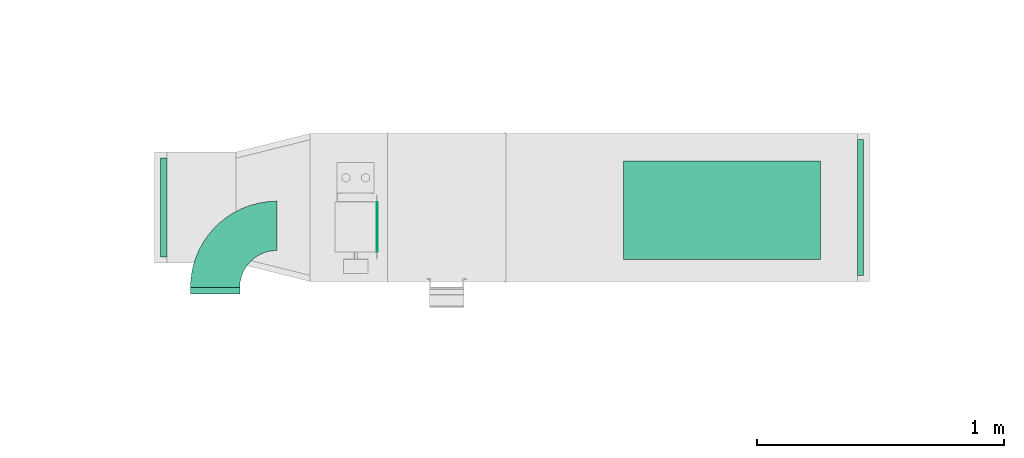
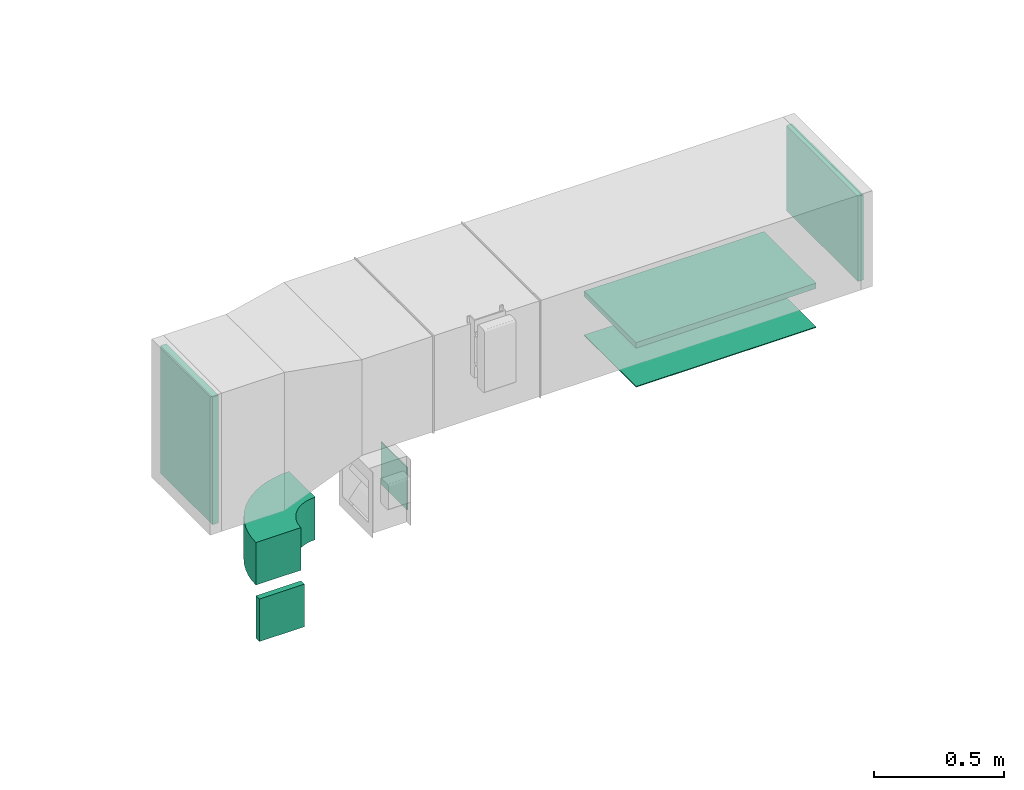
# One storey, part 5 of 10: 5 flow fittings, 2 flow terminals.
"""IFC2X3 building model written with IfcOpenShell, lengths in millimetres."""

from ifc_helpers import new_model, entity, si_unit, converted_unit, derived_unit, direction, frame, frame_2d, origin, origin_2d_with_axis, place, context, subcontext, project, spatial, polyline, circle_curve, parameter, trimmed, segment, composite_curve, rectangle, outline, extrude, source, transform, mapped, material, type_object, type_shapes, element, save


model = new_model("IFC2X3")

# Units and contexts
model_context = context("Model", 3, precision=0.01, world=origin(), true_north=direction((6.12303176911189e-17, 1.0)))
body_context = subcontext(model_context, "Body", "Model", "MODEL_VIEW")
ifc_project = project(units=[si_unit("LENGTHUNIT", "METRE", prefix="MILLI"), si_unit("AREAUNIT", "SQUARE_METRE"), si_unit("VOLUMEUNIT", "CUBIC_METRE"), converted_unit("PLANEANGLEUNIT", "DEGREE", entity("IfcRatioMeasure", 0.0174532925199433), si_unit("PLANEANGLEUNIT", "RADIAN"), dimensions=[0, 0, 0, 0, 0, 0, 0]), si_unit("MASSUNIT", "GRAM", prefix="KILO"), derived_unit("MASSDENSITYUNIT", [(si_unit("MASSUNIT", "GRAM", prefix="KILO"), 1), (si_unit("LENGTHUNIT", "METRE"), -3)]), derived_unit("MOMENTOFINERTIAUNIT", [(si_unit("LENGTHUNIT", "METRE"), 4)]), si_unit("TIMEUNIT", "SECOND"), si_unit("FREQUENCYUNIT", "HERTZ"), si_unit("THERMODYNAMICTEMPERATUREUNIT", "DEGREE_CELSIUS"), derived_unit("THERMALTRANSMITTANCEUNIT", [(si_unit("MASSUNIT", "GRAM", prefix="KILO"), 1), (si_unit("THERMODYNAMICTEMPERATUREUNIT", "KELVIN"), -1), (si_unit("TIMEUNIT", "SECOND"), -3)]), derived_unit("VOLUMETRICFLOWRATEUNIT", [(si_unit("LENGTHUNIT", "METRE"), 3), (si_unit("TIMEUNIT", "SECOND"), -1)]), derived_unit("MASSFLOWRATEUNIT", [(si_unit("MASSUNIT", "GRAM", prefix="KILO"), 1), (si_unit("TIMEUNIT", "SECOND"), -1)]), derived_unit("ROTATIONALFREQUENCYUNIT", [(si_unit("TIMEUNIT", "SECOND"), -1)]), si_unit("ELECTRICCURRENTUNIT", "AMPERE"), si_unit("ELECTRICVOLTAGEUNIT", "VOLT"), si_unit("POWERUNIT", "WATT"), si_unit("FORCEUNIT", "NEWTON", prefix="KILO"), si_unit("ILLUMINANCEUNIT", "LUX"), si_unit("LUMINOUSFLUXUNIT", "LUMEN"), si_unit("LUMINOUSINTENSITYUNIT", "CANDELA"), derived_unit("USERDEFINED", [(si_unit("MASSUNIT", "GRAM", prefix="KILO"), -1), (si_unit("LENGTHUNIT", "METRE"), -2), (si_unit("TIMEUNIT", "SECOND"), 3), (si_unit("LUMINOUSFLUXUNIT", "LUMEN"), 1)]), derived_unit("LINEARVELOCITYUNIT", [(si_unit("LENGTHUNIT", "METRE"), 1), (si_unit("TIMEUNIT", "SECOND"), -1)]), si_unit("PRESSUREUNIT", "PASCAL"), derived_unit("USERDEFINED", [(si_unit("LENGTHUNIT", "METRE"), -2), (si_unit("MASSUNIT", "GRAM", prefix="KILO"), 1), (si_unit("TIMEUNIT", "SECOND"), -2)]), derived_unit("LINEARFORCEUNIT", [(si_unit("MASSUNIT", "GRAM", prefix="KILO"), 1), (si_unit("LENGTHUNIT", "METRE"), 1), (si_unit("TIMEUNIT", "SECOND"), -2), (si_unit("LENGTHUNIT", "METRE"), -1)]), derived_unit("PLANARFORCEUNIT", [(si_unit("MASSUNIT", "GRAM", prefix="KILO"), 1), (si_unit("LENGTHUNIT", "METRE"), 1), (si_unit("TIMEUNIT", "SECOND"), -2), (si_unit("LENGTHUNIT", "METRE"), -2)])], contexts=[model_context])

# Site, building, storey
site_placement = place(None, origin())
site = spatial("IfcSite", under=ifc_project, at=site_placement, CompositionType="ELEMENT")
building_placement = place(site_placement, origin())
building = spatial("IfcBuilding", under=site, at=building_placement, CompositionType="ELEMENT")
storey_placement = place(building_placement, frame((0.0, 0.0, 8100.0)))
storey = spatial("IfcBuildingStorey", under=building, at=storey_placement, CompositionType="ELEMENT", Elevation=8100.0)

# Flow fittings
ifc_material_1 = material()
duct_fitting_type_1 = type_object("IfcDuctFittingType", PredefinedType="NOTDEFINED", material=ifc_material_1)
shared_shape_1 = source(origin(), body_context, "Body", "SweptSolid", [
    extrude(rectangle(XDim=800.0, YDim=26.096, at=origin_2d_with_axis()), frame((6.95, 0.0, -200.0), z_axis=(0.0, 0.0, 1.0), x_axis=(0.0, -1.0, 0.0)), (0.0, 0.0, 1.0), 400.0),
])
type_shapes(duct_fitting_type_1, [shared_shape_1])
flow_fitting_1_placement = place(storey_placement, frame((12300.13, 14784.08, 3000.0), z_axis=(0.0, 1.0, 0.0), x_axis=(0.0, 0.0, -1.0)))
element("IfcFlowFitting", 1, at=flow_fitting_1_placement, inside=storey, type_object=duct_fitting_type_1, material=ifc_material_1, context=body_context, shape_type="MappedRepresentation", body=[
    mapped(shared_shape_1, transform((0.0, 0.0, 0.0), scale=1.0)),
])
duct_fitting_type_2 = type_object("IfcDuctFittingType", PredefinedType="NOTDEFINED", material=ifc_material_1)
shared_shape_2 = source(origin(), body_context, "Body", "SweptSolid", [
    extrude(rectangle(XDim=24.9999999999999, YDim=550.0, at=origin_2d_with_axis()), frame((12.5, 0.0, -200.0)), (0.0, 0.0, 1.0), 400.0),
])
type_shapes(duct_fitting_type_2, [shared_shape_2])
flow_fitting_2_placement = place(storey_placement, frame((12848.49, 14795.08, 3200.0)))
element("IfcFlowFitting", 2, at=flow_fitting_2_placement, inside=storey, type_object=duct_fitting_type_2, material=ifc_material_1, context=body_context, shape_type="MappedRepresentation", body=[
    mapped(shared_shape_2, transform((0.0, 0.0, 0.0), scale=1.0)),
])
duct_fitting_type_3 = type_object("IfcDuctFittingType", PredefinedType="NOTDEFINED", material=ifc_material_1)
shared_shape_3 = source(origin(), body_context, "Body", "SweptSolid", [
    extrude(rectangle(XDim=600.0, YDim=26.096, at=origin_2d_with_axis()), frame((6.95, 0.0, -200.0), z_axis=(0.0, 0.0, 1.0), x_axis=(0.0, -1.0, 0.0)), (0.0, 0.0, 1.0), 400.0),
])
type_shapes(duct_fitting_type_3, [shared_shape_3])
flow_fitting_3_placement = place(storey_placement, frame((10029.73, 14795.08, 3100.0), z_axis=(0.0, -1.0, 0.0), x_axis=(1.0, 0.0, 0.0)))
element("IfcFlowFitting", 3, at=flow_fitting_3_placement, inside=storey, type_object=duct_fitting_type_3, material=ifc_material_1, context=body_context, shape_type="MappedRepresentation", body=[
    mapped(shared_shape_3, transform((0.0, 0.0, 0.0), scale=1.0)),
])

# Flow terminals
ifc_material_2 = material()
air_terminal_type_1 = type_object("IfcAirTerminalType", PredefinedType="NOTDEFINED", material=ifc_material_2)
shared_shape_4 = source(origin(), body_context, "Body", "SweptSolid", [
    extrude(rectangle(XDim=4.0, YDim=799.999999999999, at=origin_2d_with_axis()), frame((0.0, -2.0, -200.0), z_axis=(0.0, 0.0, 1.0), x_axis=(0.0, 1.0, 0.0)), (0.0, 0.0, 1.0), 400.000000000005),
])
type_shapes(air_terminal_type_1, [shared_shape_4])
flow_terminal_1_placement = place(storey_placement, frame((12300.13, 14784.08, 2800.0), z_axis=(0.0, 1.0, 0.0), x_axis=(-1.0, 0.0, 0.0)))
element("IfcFlowTerminal", 4, at=flow_terminal_1_placement, inside=storey, type_object=air_terminal_type_1, material=ifc_material_2, context=body_context, shape_type="MappedRepresentation", body=[
    mapped(shared_shape_4, transform((0.0, 0.0, 0.0), scale=1.0)),
])
air_terminal_type_2 = type_object("IfcAirTerminalType", PredefinedType="NOTDEFINED", material=ifc_material_2)
shared_shape_5 = source(origin(), body_context, "Body", "SweptSolid", [
    extrude(rectangle(XDim=4.0, YDim=199.999999999999, at=origin_2d_with_axis()), frame((0.0, -2.0, -100.0), z_axis=(0.0, 0.0, 1.0), x_axis=(0.0, 1.0, 0.0)), (0.0, 0.0, 1.0), 200.000000000005),
])
type_shapes(air_terminal_type_2, [shared_shape_5])
flow_terminal_2_placement = place(storey_placement, frame((10899.87, 14716.48, 2650.0), z_axis=(0.0, 0.0, 1.0), x_axis=(0.0, 1.0, 0.0)))
element("IfcFlowTerminal", 5, at=flow_terminal_2_placement, inside=storey, type_object=air_terminal_type_2, material=ifc_material_2, context=body_context, shape_type="MappedRepresentation", body=[
    mapped(shared_shape_5, transform((0.0, 0.0, 0.0), scale=1.0)),
])

# Flow fittings
duct_fitting_type_4 = type_object("IfcDuctFittingType", PredefinedType="NOTDEFINED", material=ifc_material_1)
shared_shape_6 = source(origin(), body_context, "Body", "SweptSolid", [
    extrude(rectangle(XDim=200.0, YDim=26.096, at=origin_2d_with_axis()), frame((6.95, 0.0, -100.0), z_axis=(0.0, 0.0, 1.0), x_axis=(0.0, -1.0, 0.0)), (0.0, 0.0, 1.0), 200.0),
])
type_shapes(duct_fitting_type_4, [shared_shape_6])
flow_fitting_4_placement = place(storey_placement, frame((10244.72, 14450.84, 2400.0), z_axis=(1.0, 0.0, 0.0), x_axis=(0.0, 1.0, 0.0)))
element("IfcFlowFitting", 6, at=flow_fitting_4_placement, inside=storey, type_object=duct_fitting_type_4, material=ifc_material_1, context=body_context, shape_type="MappedRepresentation", body=[
    mapped(shared_shape_6, transform((0.0, 0.0, 0.0), scale=1.0)),
])
duct_fitting_type_5 = type_object("IfcDuctFittingType", PredefinedType="NOTDEFINED", material=ifc_material_1)
shared_shape_7 = source(origin(), body_context, "Body", "SweptSolid", [
    extrude(outline(composite_curve([segment(polyline([(-225.0, -125.0), (-25.0, -125.0)]), True, "CONTINUOUS"), segment(trimmed(circle_curve(frame_2d((125.0, -125.0), x_axis=(0.0, 1.0)), 150.0), [parameter(0.0)], [parameter(90.0000000000001)], True, "PARAMETER"), False, "CONTINUOUS"), segment(polyline([(125.0, 25.0), (125.0, 225.0)]), True, "CONTINUOUS"), segment(trimmed(circle_curve(frame_2d((125.0, -125.0), x_axis=(0.0, 1.0)), 350.0), [parameter(0.0)], [parameter(90.0000000000001)], True, "PARAMETER"), True, "CONTINUOUS")], self_intersect=False)), frame((-125.0, 125.0, -100.0), z_axis=(0.0, 0.0, 1.0), x_axis=(-1.0, 0.0, 0.0)), (0.0, 0.0, 1.0), 200.0),
])
type_shapes(duct_fitting_type_5, [shared_shape_7])
flow_fitting_5_placement = place(storey_placement, frame((10244.72, 14720.84, 2650.0), z_axis=(0.0, 0.0, 1.0), x_axis=(-1.0, 0.0, 0.0)))
element("IfcFlowFitting", 7, at=flow_fitting_5_placement, inside=storey, type_object=duct_fitting_type_5, material=ifc_material_1, context=body_context, shape_type="MappedRepresentation", body=[
    mapped(shared_shape_7, transform((0.0, 0.0, 0.0), scale=1.0)),
])

save(model, "model.ifc")
